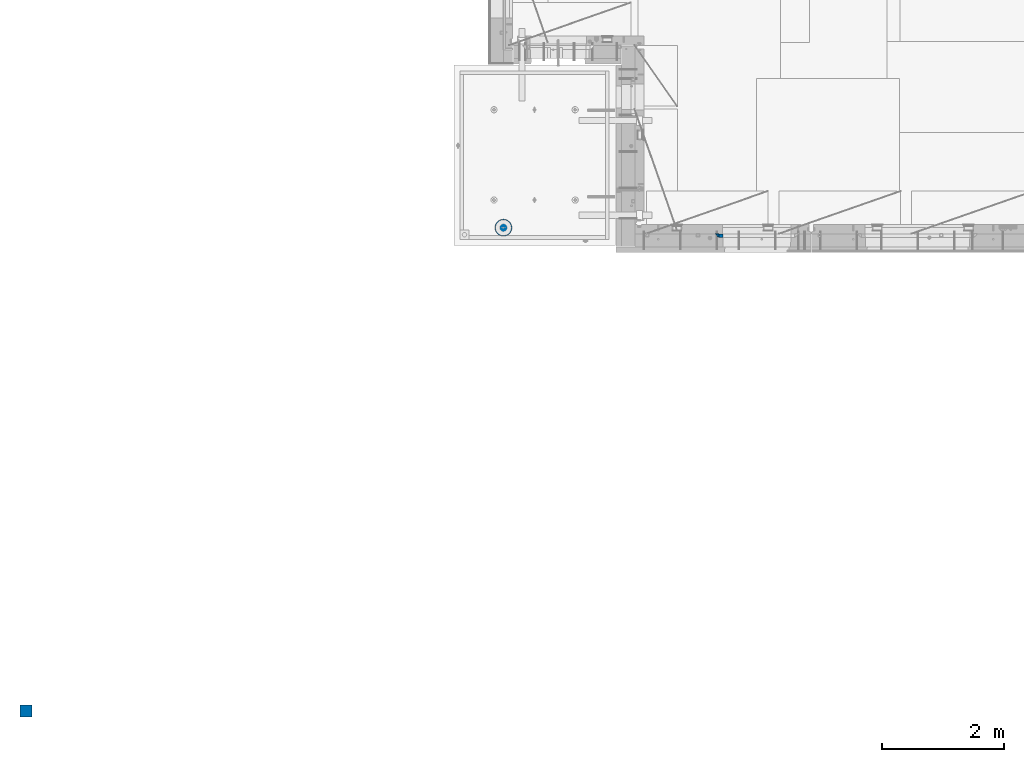
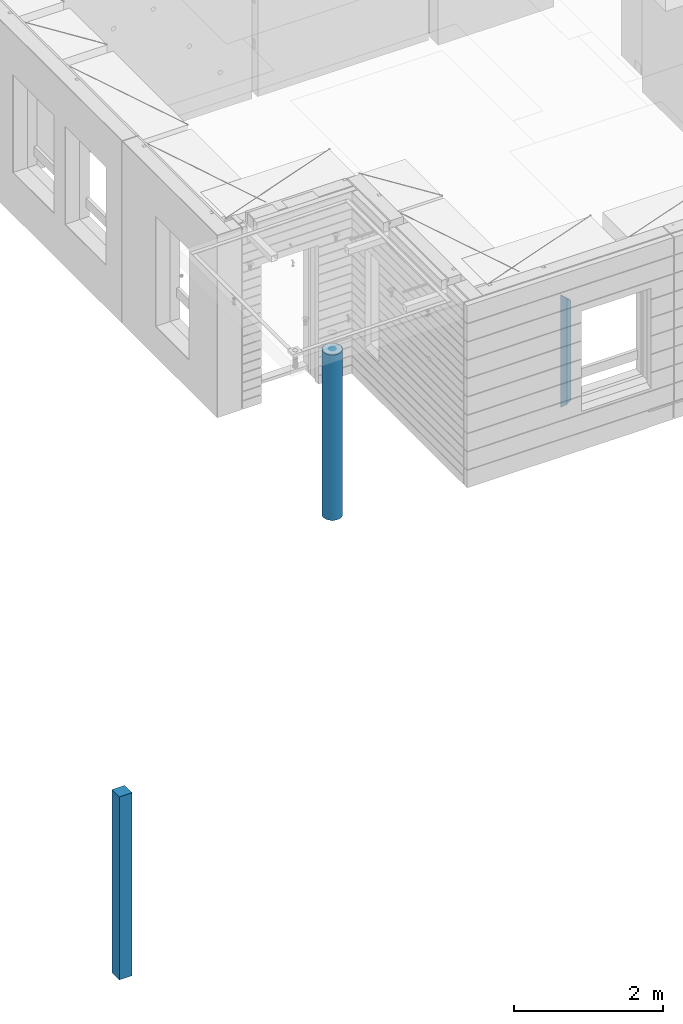
# One storey, part 1 of 350: 4 columns, 3 elements without a shape of their own.
"""IFC2X3 building model written with IfcOpenShell, lengths in millimetres."""

from ifc_helpers import new_model, si_unit, frame, origin_with_axes, place, context, subcontext, project, spatial, faceted_brep, material, type_object, element, aggregate, save


model = new_model("IFC2X3")

# Units and contexts
model_context = context("Model", 3, precision=1e-05, world=origin_with_axes())
body_context = subcontext(model_context, "Body", "Model", "MODEL_VIEW")
ifc_project = project(units=[si_unit("LENGTHUNIT", "METRE", prefix="MILLI"), si_unit("AREAUNIT", "SQUARE_METRE"), si_unit("VOLUMEUNIT", "CUBIC_METRE"), si_unit("MASSUNIT", "GRAM", prefix="KILO"), si_unit("TIMEUNIT", "SECOND"), si_unit("PLANEANGLEUNIT", "RADIAN"), si_unit("SOLIDANGLEUNIT", "STERADIAN"), si_unit("THERMODYNAMICTEMPERATUREUNIT", "DEGREE_CELSIUS"), si_unit("LUMINOUSINTENSITYUNIT", "LUMEN")], contexts=[model_context])

# Site, building, storey
site_placement = place(None, origin_with_axes())
site = spatial("IfcSite", under=ifc_project, at=site_placement, CompositionType="ELEMENT")
building_placement = place(site_placement, origin_with_axes())
building = spatial("IfcBuilding", under=site, at=building_placement, CompositionType="ELEMENT")
storey_placement = place(building_placement, origin_with_axes())
storey = spatial("IfcBuildingStorey", under=building, at=storey_placement, Name="2", CompositionType="ELEMENT", Elevation=0.0)

# Assembly, columns
assembly_1_placement = place(storey_placement, origin_with_axes())
assembly_1 = element("IfcElementAssembly", 1, at=assembly_1_placement, inside=storey, AssemblyPlace="NOTDEFINED", PredefinedType="REINFORCEMENT_UNIT")
ifc_material_1 = material(Name="CONCRETE/C25/30")
column_type_1 = type_object("IfcColumnType", PredefinedType="NOTDEFINED")
column_1_placement = place(assembly_1_placement, frame((11363.0000473781, 7820.0, 85320.0), z_axis=(1.0, 0.0, 0.0), x_axis=(0.0, 0.0, 1.0)))
column_1 = element("IfcColumn", 2, at=column_1_placement, type_object=column_type_1, material=ifc_material_1, Name="SK", context=body_context, shape_type="Brep", body=[
    faceted_brep([(1795.00000000001, -30.0, 30.0), (1855.0, -30.0, -30.0), (1795.00000000001, 30.0, 30.0), (60.0000000000073, -30.0, 30.0), (0.0, -30.0, -30.0), (60.0000000000073, 30.0, 30.0)], [[[0, 1, 2]], [[1, 0, 3, 4]], [[2, 1, 4, 5]], [[0, 2, 5, 3]], [[5, 4, 3]]]),
])
column_type_2 = type_object("IfcColumnType", PredefinedType="NOTDEFINED")
column_2_placement = place(assembly_1_placement, frame((11428.0000473781, 7820.0, 85380.0), z_axis=(1.0, 0.0, 0.0), x_axis=(0.0, 0.0, 1.0)))
column_2 = element("IfcColumn", 3, at=column_2_placement, type_object=column_type_2, material=ifc_material_1, Name="SK", context=body_context, shape_type="Brep", body=[
    faceted_brep([(1735.0, -30.0, -35.0), (1735.0, 30.0, -35.0), (1678.70623674487, 30.0, 30.6760571454033), (1680.09619813452, -30.0, 29.0544355237798), (56.2937632551329, 29.9999988381387, 30.6760571454033), (54.9038019193104, -29.9999988381387, 29.0544355865859), (0.0, -30.0, -35.0), (0.0, 30.0, -35.0)], [[[0, 1, 2, 3]], [[3, 2, 4, 5]], [[0, 3, 5, 6]], [[1, 0, 6, 7]], [[2, 1, 7, 4]], [[5, 4, 7, 6]]]),
])
aggregate(assembly_1, [column_2, column_1])

# Assembly, column
assembly_2_placement = place(storey_placement, origin_with_axes())
assembly_2 = element("IfcElementAssembly", 4, at=assembly_2_placement, inside=storey, AssemblyPlace="NOTDEFINED", PredefinedType="REINFORCEMENT_UNIT")
ifc_material_2 = material(Name="CONCRETE/Concrete_Undefined")
column_type_3 = type_object("IfcColumnType", PredefinedType="NOTDEFINED")
column_3_placement = place(assembly_2_placement, frame((0.0, 0.0, 84760.0), z_axis=(0.0, 1.0, 0.0), x_axis=(0.0, 0.0, 1.0)))
column_3 = element("IfcColumn", 5, at=column_3_placement, type_object=column_type_3, material=ifc_material_2, context=body_context, shape_type="Brep", body=[
    faceted_brep([(0.0, 100.0, -100.0), (0.0, 100.0, 100.0), (3000.0, 100.0, 100.0), (3000.0, 100.0, -100.0), (0.0, -100.0, 100.0), (3000.0, -100.0, 100.0), (0.0, -100.0, -100.0), (3000.0, -100.0, -100.0)], [[[0, 1, 2, 3]], [[1, 4, 5, 2]], [[4, 6, 7, 5]], [[6, 0, 3, 7]], [[5, 7, 3, 2]], [[6, 4, 1, 0]]]),
])
aggregate(assembly_2, [column_3])

assembly_3_placement = place(storey_placement, origin_with_axes())
assembly_3 = element("IfcElementAssembly", 6, at=assembly_3_placement, inside=storey, AssemblyPlace="NOTDEFINED", PredefinedType="REINFORCEMENT_UNIT")
ifc_material_3 = material(Name="CONCRETE/C30/37")
column_type_4 = type_object("IfcColumnType", Name="D280", PredefinedType="NOTDEFINED")
column_4_placement = place(assembly_3_placement, frame((7849.99879520436, 7949.98488883804, 84725.0), z_axis=(-1.0, 3.00000001838171e-08, 0.0), x_axis=(0.0, 0.0, 1.0)))
column_4 = element("IfcColumn", 7, at=column_4_placement, type_object=column_type_4, material=ifc_material_3, ObjectType="D280", context=body_context, shape_type="Brep", body=[
    faceted_brep([(0.0, -140.0, 0.0), (0.0, -136.489907705454, -31.1529307538876), (2710.0, -136.489907705454, -31.1529307538876), (2710.0, -140.0, 0.0), (0.0, -126.135641506338, -60.7437234764584), (2710.0, -126.135641506338, -60.7437234764584), (0.0, -109.456407545524, -87.2885722602223), (2710.0, -109.456407545524, -87.2885722602223), (0.0, -87.2885722602223, -109.456407545527), (2710.0, -87.2885722602223, -109.456407545527), (0.0, -60.7437234764584, -126.135641506342), (2710.0, -60.7437234764584, -126.135641506342), (0.0, -31.152930753884, -136.489907705458), (2710.0, -31.152930753884, -136.489907705458), (0.0, 0.0, -140.0), (2710.0, 0.0, -140.0), (0.0, 31.152930753884, -136.489907705458), (2710.0, 31.152930753884, -136.489907705458), (0.0, 60.7437234764584, -126.135641506342), (2710.0, 60.7437234764584, -126.135641506342), (0.0, 87.2885722602223, -109.456407545527), (2710.0, 87.2885722602223, -109.456407545527), (0.0, 109.456407545524, -87.2885722602223), (2710.0, 109.456407545524, -87.2885722602223), (0.0, 126.135641506338, -60.7437234764584), (2710.0, 126.135641506338, -60.7437234764584), (0.0, 136.489907705454, -31.1529307538876), (2710.0, 136.489907705454, -31.1529307538876), (0.0, 140.0, 0.0), (2710.0, 140.0, 0.0), (0.0, 136.489907705454, 31.1529307538876), (2710.0, 136.489907705454, 31.1529307538876), (0.0, 126.135641506338, 60.7437234764584), (2710.0, 126.135641506338, 60.7437234764584), (0.0, 109.456407545524, 87.2885722602223), (2710.0, 109.456407545524, 87.2885722602223), (0.0, 87.2885722602223, 109.456407545527), (2710.0, 87.2885722602223, 109.456407545527), (0.0, 60.7437234764584, 126.135641506342), (2710.0, 60.7437234764584, 126.135641506342), (0.0, 31.152930753884, 136.489907705458), (2710.0, 31.152930753884, 136.489907705458), (0.0, 0.0, 140.0), (2710.0, 0.0, 140.0), (0.0, -31.152930753884, 136.489907705458), (2710.0, -31.152930753884, 136.489907705458), (0.0, -60.7437234764584, 126.135641506342), (2710.0, -60.7437234764584, 126.135641506342), (0.0, -87.2885722602223, 109.456407545527), (2710.0, -87.2885722602223, 109.456407545527), (0.0, -109.456407545524, 87.2885722602223), (2710.0, -109.456407545524, 87.2885722602223), (0.0, -126.135641506338, 60.7437234764584), (2710.0, -126.135641506338, 60.7437234764584), (0.0, -136.489907705454, 31.1529307538876), (2710.0, -136.489907705454, 31.1529307538876)], [[[0, 1, 2, 3]], [[1, 4, 5, 2]], [[4, 6, 7, 5]], [[6, 8, 9, 7]], [[8, 10, 11, 9]], [[10, 12, 13, 11]], [[12, 14, 15, 13]], [[14, 16, 17, 15]], [[16, 18, 19, 17]], [[18, 20, 21, 19]], [[20, 22, 23, 21]], [[22, 24, 25, 23]], [[24, 26, 27, 25]], [[26, 28, 29, 27]], [[28, 30, 31, 29]], [[30, 32, 33, 31]], [[32, 34, 35, 33]], [[34, 36, 37, 35]], [[36, 38, 39, 37]], [[38, 40, 41, 39]], [[40, 42, 43, 41]], [[42, 44, 45, 43]], [[44, 46, 47, 45]], [[46, 48, 49, 47]], [[48, 50, 51, 49]], [[50, 52, 53, 51]], [[52, 54, 55, 53]], [[54, 0, 3, 55]], [[5, 7, 9, 11, 13, 15, 17, 19, 21, 23, 25, 27, 29, 31, 33, 35, 37, 39, 41, 43, 45, 47, 49, 51, 53, 55, 3, 2]], [[54, 52, 50, 48, 46, 44, 42, 40, 38, 36, 34, 32, 30, 28, 26, 24, 22, 20, 18, 16, 14, 12, 10, 8, 6, 4, 1, 0]]]),
])
aggregate(assembly_3, [column_4])

save(model, "model.ifc")
